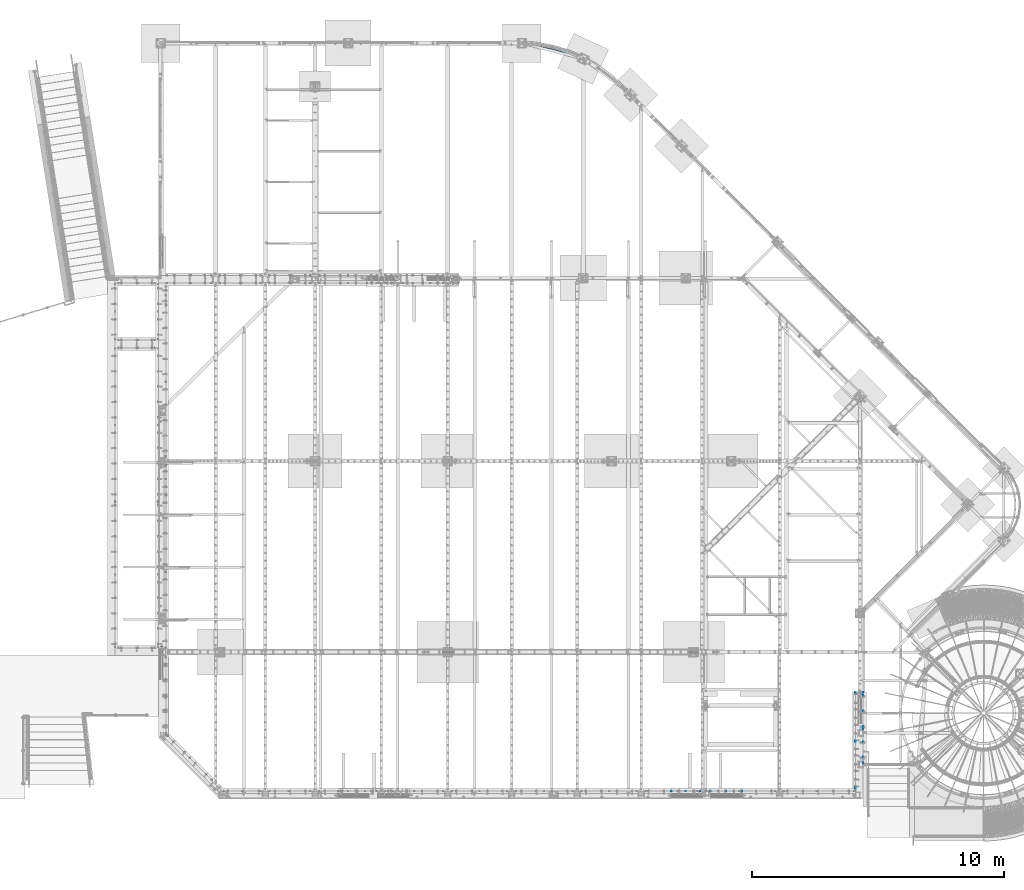
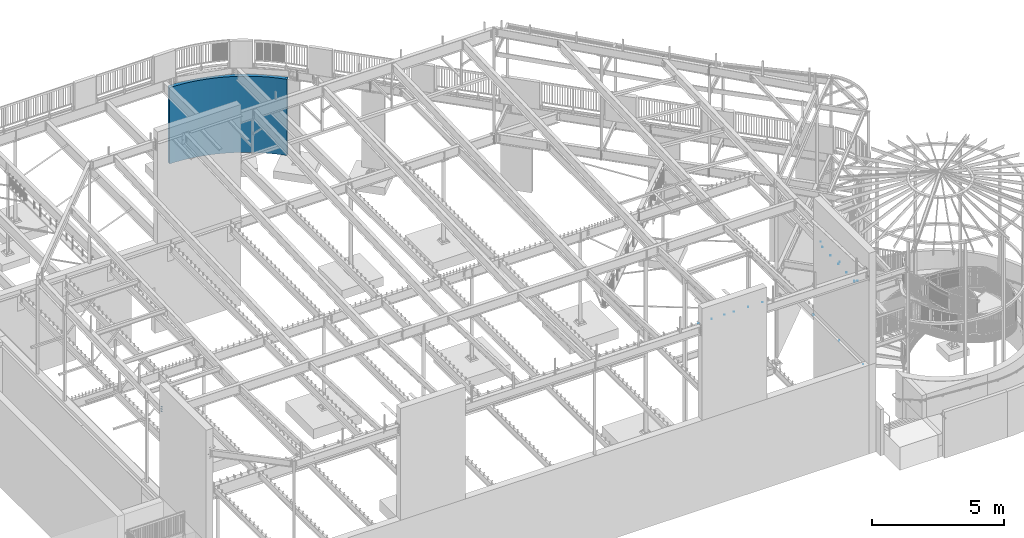
# One storey, part 942 of 975: 6 mechanical fasteners, 1 wall.
"""IFC2X3 building model written with IfcOpenShell, lengths in millimetres."""

from ifc_helpers import new_model, si_unit, frame, origin_with_axes, place, context, subcontext, project, spatial, faceted_brep, source, transform, mapped, material, type_object, element, save


model = new_model("IFC2X3")

# Units and contexts
model_context = context("Model", 3, precision=1e-05, world=origin_with_axes())
body_context = subcontext(model_context, "Body", "Model", "MODEL_VIEW")
ifc_project = project(units=[si_unit("LENGTHUNIT", "METRE", prefix="MILLI"), si_unit("AREAUNIT", "SQUARE_METRE"), si_unit("VOLUMEUNIT", "CUBIC_METRE"), si_unit("MASSUNIT", "GRAM", prefix="KILO"), si_unit("TIMEUNIT", "SECOND"), si_unit("PLANEANGLEUNIT", "RADIAN"), si_unit("SOLIDANGLEUNIT", "STERADIAN"), si_unit("THERMODYNAMICTEMPERATUREUNIT", "DEGREE_CELSIUS"), si_unit("LUMINOUSINTENSITYUNIT", "LUMEN")], contexts=[model_context])

# Site, building, storey
site_placement = place(None, origin_with_axes())
site = spatial("IfcSite", under=ifc_project, at=site_placement, CompositionType="ELEMENT")
building_placement = place(site_placement, origin_with_axes())
building = spatial("IfcBuilding", under=site, at=building_placement, Name="Undefined", CompositionType="ELEMENT")
storey_placement = place(building_placement, origin_with_axes())
storey = spatial("IfcBuildingStorey", under=building, at=storey_placement, Name="Undefined", CompositionType="ELEMENT", Elevation=0.0)

# Wall
ifc_material_1 = material(Name="CONCRETE/5000")
wall_type = type_object("IfcWallType", PredefinedType="NOTDEFINED")
wall_placement = place(storey_placement, frame((16265.9279473487, 29962.475, 1765.3), z_axis=(0.0, 0.0, 1.0), x_axis=(0.920632077807922, -0.390431270918542, 0.0)))
element("IfcWall", 1, at=wall_placement, inside=storey, type_object=wall_type, material=ifc_material_1, Name="STUD WALL", context=body_context, shape_type="Brep", body=[
    faceted_brep([(-29.014480485997, 70.4599171310983, -1765.3), (-29.014480485997, 70.4599171310983, 1765.3), (191.038909126074, 156.087803173992, 1765.3), (191.038909126074, 156.087803173992, -1765.3), (29.0144804859979, -70.4599171310911, 1765.3), (29.0144804859979, -70.4599171310911, -1765.3), (243.520305654064, 13.0092827090339, -1765.3), (243.520305654064, 13.0092827090339, 1765.3), (414.268430151377, 233.056693582781, 1765.3), (414.268430151377, 233.056693582781, -1765.3), (461.122191695533, 88.0377809226484, -1765.3), (461.122191695533, 88.0377809226484, 1765.3), (640.333502699951, 301.249157400722, 1765.3), (640.333502699951, 301.249157400722, -1765.3), (681.488144768097, 154.511106997277, -1765.3), (681.488144768097, 154.511106997277, 1765.3), (868.889220698546, 360.561153810486, 1765.3), (868.889220698546, 360.561153810486, -1765.3), (904.281953909582, 212.327842993349, -1765.3), (904.281953909582, 212.327842993349, 1765.3), (1099.58687811165, 410.902190868524, 1765.3), (1099.58687811165, 410.902190868524, -1765.3), (1129.16370399294, 261.39977827682, -1765.3), (1129.16370399294, 261.39977827682, 1765.3), (1332.07450096012, 452.19546356814, 1765.3), (1332.07450096012, 452.19546356814, -1765.3), (1355.79029433263, 301.652044101647, -1765.3), (1355.79029433263, 301.652044101647, 1765.3), (1565.99738432573, 484.377971020338, 1765.3), (1565.99738432573, 484.377971020338, -1765.3), (1583.8159621512, 333.023227836566, -1765.3), (1583.8159621512, 333.023227836566, 1765.3), (1800.99863352217, 507.400612573932, 1765.3), (1800.99863352217, 507.400612573932, -1765.3), (1812.8928101074, 355.465466661917, -1765.3), (1812.8928101074, 355.465466661917, 1765.3), (2036.71970860714, 521.228262728087, 1765.3), (2036.71970860714, 521.228262728087, -1765.3), (2042.67133708099, 368.944520593701, -1765.3), (2042.67133708099, 368.944520593701, 1765.3), (2272.80097140444, 525.839824723094, 1765.3), (2272.80097140444, 525.839824723094, -1765.3), (2272.80097140441, 373.439824723282, -1765.3), (2272.80097140441, 373.439824723282, 1765.3), (2508.88223420175, 521.22826272752, 1765.3), (2508.88223420175, 521.22826272752, -1765.3), (2502.93060572783, 368.944520593148, -1765.3), (2502.93060572783, 368.944520593148, 1765.3), (2744.60330928671, 507.40061257279, 1765.3), (2744.60330928671, 507.40061257279, -1765.3), (2732.70913270141, 355.465466660804, -1765.3), (2732.70913270141, 355.465466660804, 1765.3), (2979.60455848314, 484.377971018628, 1765.3), (2979.60455848314, 484.377971018628, -1765.3), (2961.78598065759, 333.023227834899, -1765.3), (2961.78598065759, 333.023227834899, 1765.3), (3213.52744184873, 452.195463565862, 1765.3), (3213.52744184873, 452.195463565862, -1765.3), (3189.81164847615, 301.652044099435, -1765.3), (3189.81164847615, 301.652044099435, 1765.3), (3446.01506469719, 410.902190865694, 1765.3), (3446.01506469719, 410.902190865694, -1765.3), (3416.43823881582, 261.399778274055, -1765.3), (3416.43823881582, 261.399778274055, 1765.3), (3676.71272211026, 360.561153807088, 1765.3), (3676.71272211026, 360.561153807088, -1765.3), (3641.31998889916, 212.327842990038, -1765.3), (3641.31998889916, 212.327842990038, 1765.3), (3905.26844010883, 301.249157396778, 1765.3), (3905.26844010883, 301.249157396778, -1765.3), (3864.11379804061, 154.511106993436, -1765.3), (3864.11379804061, 154.511106993436, 1765.3), (4131.33351265737, 233.056693578284, 1765.3), (4131.33351265737, 233.056693578284, -1765.3), (4084.47975111314, 88.037780918261, -1765.3), (4084.47975111314, 88.037780918261, 1765.3), (4354.56303368264, 156.087803168957, 1765.3), (4354.56303368264, 156.087803168957, -1765.3), (4302.08163715458, 13.0092827041299, -1765.3), (4302.08163715458, 13.0092827041299, 1765.3), (4574.61642329466, 70.4599171255322, 1765.3), (4574.61642329466, 70.4599171255322, -1765.3), (4516.5874623226, -70.4599171365116, 1765.3), (4516.5874623226, -70.4599171365116, -1765.3)], [[[0, 1, 2, 3]], [[4, 5, 6, 7]], [[5, 4, 1, 0]], [[3, 2, 8, 9]], [[7, 6, 10, 11]], [[9, 8, 12, 13]], [[11, 10, 14, 15]], [[13, 12, 16, 17]], [[15, 14, 18, 19]], [[17, 16, 20, 21]], [[19, 18, 22, 23]], [[21, 20, 24, 25]], [[23, 22, 26, 27]], [[25, 24, 28, 29]], [[27, 26, 30, 31]], [[29, 28, 32, 33]], [[31, 30, 34, 35]], [[33, 32, 36, 37]], [[35, 34, 38, 39]], [[37, 36, 40, 41]], [[39, 38, 42, 43]], [[41, 40, 44, 45]], [[43, 42, 46, 47]], [[45, 44, 48, 49]], [[47, 46, 50, 51]], [[49, 48, 52, 53]], [[51, 50, 54, 55]], [[53, 52, 56, 57]], [[55, 54, 58, 59]], [[57, 56, 60, 61]], [[59, 58, 62, 63]], [[61, 60, 64, 65]], [[63, 62, 66, 67]], [[65, 64, 68, 69]], [[67, 66, 70, 71]], [[69, 68, 72, 73]], [[71, 70, 74, 75]], [[73, 72, 76, 77]], [[75, 74, 78, 79]], [[77, 76, 80, 81]], [[76, 72, 68, 64, 60, 56, 52, 48, 44, 40, 36, 32, 28, 24, 20, 16, 12, 8, 2, 1, 4, 7, 11, 15, 19, 23, 27, 31, 35, 39, 43, 47, 51, 55, 59, 63, 67, 71, 75, 79, 82, 80]], [[79, 78, 83, 82]], [[78, 74, 70, 66, 62, 58, 54, 50, 46, 42, 38, 34, 30, 26, 22, 18, 14, 10, 6, 5, 0, 3, 9, 13, 17, 21, 25, 29, 33, 37, 41, 45, 49, 53, 57, 61, 65, 69, 73, 77, 81, 83]], [[82, 83, 81, 80]]]),
])

# Mechanical fasteners
ifc_material_2 = material(Name="Undefined")
mechanical_fastener_type = type_object("IfcMechanicalFastenerType", Name="Bolt assembly")
shared_shape_1 = source(origin_with_axes(), body_context, "Body", "Brep", [
    faceted_brep([(21.0805021442695, -33.3374996185303, 0.0), (10.5402510721348, -33.3374996185303, 18.2562503814697), (-10.5402510721347, -33.3374996185303, 18.2562503814697), (-21.0805021442695, -33.3374996185303, 2.58161694753986e-15), (-10.5402510721348, -33.3374996185303, -18.2562503814697), (10.5402510721347, -33.3374996185303, -18.2562503814697), (10.5402510721347, -19.84375, -18.2562503814697), (-10.5402510721348, -19.84375, -18.2562503814697), (-21.0805021442695, -19.84375, 2.58161694753986e-15), (-10.5402510721347, -19.84375, 18.2562503814697), (10.5402510721348, -19.84375, 18.2562503814697), (21.0805021442695, -19.84375, 0.0), (11.1125001907349, -19.84375, 0.0), (9.62370746473562, -19.84375, 5.55625009536776), (5.55625009536677, -19.84375, 9.62370746473619), (-1.1516283793199e-12, -19.84375, 11.1125001907349), (-5.55625009536876, -19.84375, 9.62370746473505), (-9.62370746473677, -19.84375, 5.55625009536577), (-11.1125001907349, -19.84375, -2.3032567586398e-12), (-9.62370746473447, -19.84375, -5.55625009536975), (-5.55625009536478, -19.84375, -9.62370746473734), (3.44254778438679e-12, -19.84375, -11.1125001907349), (5.55625009537075, -19.84375, -9.6237074647339), (9.62370746473792, -19.84375, -5.55625009536378), (9.62370746473792, 37.3062492458346, -5.55625009536378), (5.55625009537075, 37.3062492458346, -9.6237074647339), (3.44254778438679e-12, 37.3062492458346, -11.1125001907349), (-5.55625009536478, 37.3062492458346, -9.62370746473734), (-9.62370746473447, 37.3062492458346, -5.55625009536975), (-11.1125001907349, 37.3062492458346, -2.3032567586398e-12), (-9.62370746473677, 37.3062492458346, 5.55625009536577), (-5.55625009536876, 37.3062492458346, 9.62370746473505), (-1.1516283793199e-12, 37.3062492458346, 11.1125001907349), (5.55625009536677, 37.3062492458346, 9.62370746473619), (9.62370746473562, 37.3062492458346, 5.55625009536776), (11.1125001907349, 37.3062492458346, 0.0), (22.2250003814697, 3.96874999999636, 0.0), (19.2474149294712, 3.96874999999636, 11.1125001907355), (11.1125001907335, 3.96874999999636, 19.2474149294724), (-2.3032567586398e-12, 3.96874999999636, 22.2250003814697), (-11.1125001907375, 3.96874999999636, 19.2474149294701), (-19.2474149294735, 3.96874999999636, 11.1125001907315), (-22.2250003814697, 3.96874999999636, -4.60651351727959e-12), (-19.2474149294689, 3.96874999999636, -11.1125001907395), (-11.1125001907296, 3.96874999999636, -19.2474149294747), (6.88509556877358e-12, 3.96874999999636, -22.2250003814697), (11.1125001907415, 3.96874999999636, -19.2474149294678), (19.2474149294758, 3.96874999999636, -11.1125001907276), (19.2474149294758, 7.34218740462893, -11.1125001907276), (11.1125001907415, 7.34218740462893, -19.2474149294678), (6.88509556877358e-12, 7.34218740462893, -22.2250003814697), (-11.1125001907296, 7.34218740462893, -19.2474149294747), (-19.2474149294689, 7.34218740462893, -11.1125001907395), (-22.2250003814697, 7.34218740462893, -4.60651351727959e-12), (-19.2474149294735, 7.34218740462893, 11.1125001907315), (-11.1125001907375, 7.34218740462893, 19.2474149294701), (-2.3032567586398e-12, 7.34218740462893, 22.2250003814697), (11.1125001907335, 7.34218740462893, 19.2474149294724), (19.2474149294712, 7.34218740462893, 11.1125001907355), (22.2250003814697, 7.34218740462893, 0.0), (21.0805021442695, 7.34218740462893, 0.0), (10.5402510721348, 7.34218740462893, 18.2562503814697), (-10.5402510721347, 7.34218740462893, 18.2562503814697), (-21.0805021442695, 7.34218740462893, 2.58161694753986e-15), (-10.5402510721348, 7.34218740462893, -18.2562503814697), (10.5402510721347, 7.34218740462893, -18.2562503814697), (10.5402510721347, 29.5671877860987, -18.2562503814697), (-10.5402510721348, 29.5671877860987, -18.2562503814697), (-21.0805021442695, 29.5671877860987, 2.58161694753986e-15), (-10.5402510721347, 29.5671877860987, 18.2562503814697), (10.5402510721348, 29.5671877860987, 18.2562503814697), (21.0805021442695, 29.5671877860987, 0.0)], [[[0, 1, 2, 3, 4, 5]], [[6, 7, 8, 9, 10, 11]], [[0, 11, 10, 1]], [[1, 10, 9, 2]], [[2, 9, 8, 3]], [[3, 8, 7, 4]], [[4, 7, 6, 5]], [[5, 6, 11, 0]], [[12, 13, 14, 15, 16, 17, 18, 19, 20, 21, 22, 23]], [[24, 25, 26, 27, 28, 29, 30, 31, 32, 33, 34, 35]], [[12, 35, 34, 13]], [[13, 34, 33, 14]], [[14, 33, 32, 15]], [[15, 32, 31, 16]], [[16, 31, 30, 17]], [[17, 30, 29, 18]], [[18, 29, 28, 19]], [[19, 28, 27, 20]], [[20, 27, 26, 21]], [[21, 26, 25, 22]], [[22, 25, 24, 23]], [[23, 24, 35, 12]], [[36, 37, 38, 39, 40, 41, 42, 43, 44, 45, 46, 47]], [[48, 49, 50, 51, 52, 53, 54, 55, 56, 57, 58, 59]], [[36, 59, 58, 37]], [[37, 58, 57, 38]], [[38, 57, 56, 39]], [[39, 56, 55, 40]], [[40, 55, 54, 41]], [[41, 54, 53, 42]], [[42, 53, 52, 43]], [[43, 52, 51, 44]], [[44, 51, 50, 45]], [[45, 50, 49, 46]], [[46, 49, 48, 47]], [[47, 48, 59, 36]], [[60, 61, 62, 63, 64, 65]], [[66, 67, 68, 69, 70, 71]], [[60, 71, 70, 61]], [[61, 70, 69, 62]], [[62, 69, 68, 63]], [[63, 68, 67, 64]], [[64, 67, 66, 65]], [[65, 66, 71, 60]]]),
    faceted_brep([(11.90625, -4.0687499258398, 0.0), (10.3111149638083, -4.0687499258398, 5.95312500000036), (5.95312499999929, -4.0687499258398, 10.3111149638089), (-1.23388752809288e-12, -4.0687499258398, 11.90625), (-5.95312500000142, -4.0687499258398, 10.3111149638077), (-10.3111149638095, -4.0687499258398, 5.95312499999822), (-11.90625, -4.0687499258398, -2.46777505618577e-12), (-10.311114963807, -4.0687499258398, -5.95312500000249), (-5.95312499999716, -4.0687499258398, -10.3111149638101), (3.68844399139171e-12, -4.0687499258398, -11.90625), (5.95312500000355, -4.0687499258398, -10.3111149638064), (10.3111149638107, -4.0687499258398, -5.95312499999609), (10.3111149638107, 3.96874999999636, -5.95312499999609), (5.95312500000355, 3.96874999999636, -10.3111149638064), (3.68844399139171e-12, 3.96874999999636, -11.90625), (-5.95312499999716, 3.96874999999636, -10.3111149638101), (-10.311114963807, 3.96874999999636, -5.95312500000249), (-11.90625, 3.96874999999636, -2.46777505618577e-12), (-10.3111149638095, 3.96874999999636, 5.95312499999822), (-5.95312500000142, 3.96874999999636, 10.3111149638077), (-1.23388752809288e-12, 3.96874999999636, 11.90625), (5.95312499999929, 3.96874999999636, 10.3111149638089), (10.3111149638083, 3.96874999999636, 5.95312500000036), (11.90625, 3.96874999999636, 0.0), (11.90625, -19.74375, 0.0), (10.3111149638083, -19.74375, 5.95312500000036), (5.95312499999929, -19.74375, 10.3111149638089), (-1.23388752809288e-12, -19.74375, 11.90625), (-5.95312500000142, -19.74375, 10.3111149638077), (-10.3111149638095, -19.74375, 5.95312499999822), (-11.90625, -19.74375, -2.46777505618577e-12), (-10.311114963807, -19.74375, -5.95312500000249), (-5.95312499999716, -19.74375, -10.3111149638101), (3.68844399139171e-12, -19.74375, -11.90625), (5.95312500000355, -19.74375, -10.3111149638064), (10.3111149638107, -19.74375, -5.95312499999609), (10.3111149638107, -3.86874999991632, -5.95312499999609), (5.95312500000355, -3.86874999991632, -10.3111149638064), (3.68844399139171e-12, -3.86874999991632, -11.90625), (-5.95312499999716, -3.86874999991632, -10.3111149638101), (-10.311114963807, -3.86874999991632, -5.95312500000249), (-11.90625, -3.86874999991632, -2.46777505618577e-12), (-10.3111149638095, -3.86874999991632, 5.95312499999822), (-5.95312500000142, -3.86874999991632, 10.3111149638077), (-1.23388752809288e-12, -3.86874999991632, 11.90625), (5.95312499999929, -3.86874999991632, 10.3111149638089), (10.3111149638083, -3.86874999991632, 5.95312500000036), (11.90625, -3.86874999991632, 0.0)], [[[0, 1, 2, 3, 4, 5, 6, 7, 8, 9, 10, 11]], [[12, 13, 14, 15, 16, 17, 18, 19, 20, 21, 22, 23]], [[0, 23, 22, 1]], [[1, 22, 21, 2]], [[2, 21, 20, 3]], [[3, 20, 19, 4]], [[4, 19, 18, 5]], [[5, 18, 17, 6]], [[6, 17, 16, 7]], [[7, 16, 15, 8]], [[8, 15, 14, 9]], [[9, 14, 13, 10]], [[10, 13, 12, 11]], [[11, 12, 23, 0]], [[24, 25, 26, 27, 28, 29, 30, 31, 32, 33, 34, 35]], [[36, 37, 38, 39, 40, 41, 42, 43, 44, 45, 46, 47]], [[24, 47, 46, 25]], [[25, 46, 45, 26]], [[26, 45, 44, 27]], [[27, 44, 43, 28]], [[28, 43, 42, 29]], [[29, 42, 41, 30]], [[30, 41, 40, 31]], [[31, 40, 39, 32]], [[32, 39, 38, 33]], [[33, 38, 37, 34]], [[34, 37, 36, 35]], [[35, 36, 47, 24]]]),
])
mechanical_fastener_1_placement = place(storey_placement, frame((2143.12508094394, 6045.01552709396, 8162.30490112537), z_axis=(0.0, 0.999999863618581, 0.000522266999802014), x_axis=(0.0, 0.00052226699980215, -0.999999863618581)))
element("IfcMechanicalFastener", 2, at=mechanical_fastener_1_placement, inside=storey, type_object=mechanical_fastener_type, material=ifc_material_2, Name="Bolt assembly", NominalDiameter=22.2250003814697, NominalLength=57.1500015258789, context=body_context, shape_type="MappedRepresentation", body=[
    mapped(shared_shape_1, transform((0.0, 0.0, 0.0))),
    mapped(shared_shape_1, transform((76.1999969482422, 0.0, 0.0))),
    mapped(shared_shape_1, transform((152.399993896484, 0.0, 0.0))),
    mapped(shared_shape_1, transform((228.600006103516, 0.0, 0.0))),
])
shared_shape_2 = source(origin_with_axes(), body_context, "Body", "Brep", [
    faceted_brep([(3.17499995231628, -6.84956091845379e-10, 0.0), (2.74963061572023, -6.84956091845379e-10, 1.58749997615824), (1.58749997615795, -6.84956091845379e-10, 2.74963061572039), (-3.29036669216467e-13, -6.84956091845379e-10, 3.17499995231628), (-1.58749997615852, -6.84956091845379e-10, 2.74963061572006), (-2.74963061572056, -6.84956091845379e-10, 1.58749997615767), (-3.17499995231628, -6.84956091845379e-10, -6.58073338432935e-13), (-2.7496306157199, -6.84956091845379e-10, -1.58749997615881), (-1.58749997615738, -6.84956091845379e-10, -2.74963061572072), (9.83585049599157e-13, -6.84956091845379e-10, -3.17499995231628), (1.58749997615909, -6.84956091845379e-10, -2.74963061571974), (2.74963061572089, -6.84956091845379e-10, -1.5874999761571), (2.74963061572089, 8.03749999952222, -1.5874999761571), (1.58749997615909, 8.03749999952222, -2.74963061571974), (9.83585049599157e-13, 8.03749999952222, -3.17499995231628), (-1.58749997615738, 8.03749999952222, -2.74963061572072), (-2.7496306157199, 8.03749999952222, -1.58749997615881), (-3.17499995231628, 8.03749999952222, -6.58073338432935e-13), (-2.74963061572056, 8.03749999952222, 1.58749997615767), (-1.58749997615852, 8.03749999952222, 2.74963061572006), (-3.29036669216467e-13, 8.03749999952222, 3.17499995231628), (1.58749997615795, 8.03749999952222, 2.74963061572039), (2.74963061572023, 8.03749999952222, 1.58749997615824), (3.17499995231628, 8.03749999952222, 0.0)], [[[0, 1, 2, 3, 4, 5, 6, 7, 8, 9, 10, 11]], [[12, 13, 14, 15, 16, 17, 18, 19, 20, 21, 22, 23]], [[0, 23, 22, 1]], [[1, 22, 21, 2]], [[2, 21, 20, 3]], [[3, 20, 19, 4]], [[4, 19, 18, 5]], [[5, 18, 17, 6]], [[6, 17, 16, 7]], [[7, 16, 15, 8]], [[8, 15, 14, 9]], [[9, 14, 13, 10]], [[10, 13, 12, 11]], [[11, 12, 23, 0]]]),
])
mechanical_fastener_2_placement = place(storey_placement, frame((29967.2373507587, 1425.65191388594, 7046.27270074789), z_axis=(-7.0905516622588e-09, -0.0430877640020049, 0.999071291046494), x_axis=(-8.50000000943246e-08, 0.999071290960394, 0.0430877659982918)))
element("IfcMechanicalFastener", 3, at=mechanical_fastener_2_placement, inside=storey, type_object=mechanical_fastener_type, material=ifc_material_2, Name="Bolt assembly", NominalDiameter=6.34999990463257, NominalLength=7.9375, context=body_context, shape_type="MappedRepresentation", body=[
    mapped(shared_shape_2, transform((0.0, 0.0, 0.0))),
    mapped(shared_shape_2, transform((1346.19995117216, -1.77897163666785e-09, -1.36424205265939e-11))),
    mapped(shared_shape_2, transform((2794.00000000059, -3.69618646800518e-09, -2.81943357549608e-11))),
])
shared_shape_3 = source(origin_with_axes(), body_context, "Body", "Brep", [
    faceted_brep([(3.96875, -0.000311037082383336, 0.0), (3.43703832126942, -0.000311037082383336, 1.98437500000012), (1.98437499999976, -0.000311037082383336, 3.43703832126963), (-4.11295842697628e-13, -0.000311037082383336, 3.96875), (-1.98437500000047, -0.000311037082383336, 3.43703832126922), (-3.43703832126983, -0.000311037082383336, 1.98437499999941), (-3.96875, -0.000311037082383336, -8.22591685395256e-13), (-3.43703832126901, -0.000311037082383336, -1.98437500000083), (-1.98437499999905, -0.000311037082383336, -3.43703832127004), (1.2294813304639e-12, -0.000311037082383336, -3.96875), (1.98437500000118, -0.000311037082383336, -3.43703832126881), (3.43703832127024, -0.000311037082383336, -1.9843749999987), (3.43703832127024, 8.03718896291767, -1.9843749999987), (1.98437500000118, 8.03718896291767, -3.43703832126881), (1.2294813304639e-12, 8.03718896291767, -3.96875), (-1.98437499999905, 8.03718896291767, -3.43703832127004), (-3.43703832126901, 8.03718896291767, -1.98437500000083), (-3.96875, 8.03718896291767, -8.22591685395256e-13), (-3.43703832126983, 8.03718896291767, 1.98437499999941), (-1.98437500000047, 8.03718896291767, 3.43703832126922), (-4.11295842697628e-13, 8.03718896291767, 3.96875), (1.98437499999976, 8.03718896291767, 3.43703832126963), (3.43703832126942, 8.03718896291767, 1.98437500000012), (3.96875, 8.03718896291767, 0.0)], [[[0, 1, 2, 3, 4, 5, 6, 7, 8, 9, 10, 11]], [[12, 13, 14, 15, 16, 17, 18, 19, 20, 21, 22, 23]], [[0, 23, 22, 1]], [[1, 22, 21, 2]], [[2, 21, 20, 3]], [[3, 20, 19, 4]], [[4, 19, 18, 5]], [[5, 18, 17, 6]], [[6, 17, 16, 7]], [[7, 16, 15, 8]], [[8, 15, 14, 9]], [[9, 14, 13, 10]], [[10, 13, 12, 11]], [[11, 12, 23, 0]]]),
])
mechanical_fastener_3_placement = place(storey_placement, frame((24530.0499815415, 304.800313270969, 8420.1), z_axis=(-0.999999999999998, 6.90000001668524e-08, 0.0), x_axis=(0.0, 0.0, 1.0)))
element("IfcMechanicalFastener", 4, at=mechanical_fastener_3_placement, inside=storey, type_object=mechanical_fastener_type, material=ifc_material_2, Name="Bolt assembly", NominalDiameter=6.34999990463257, NominalLength=7.9375, context=body_context, shape_type="MappedRepresentation", body=[
    mapped(shared_shape_3, transform((0.0, 0.0, -625.474975585938))),
    mapped(shared_shape_3, transform((0.0, 0.0, 0.0))),
    mapped(shared_shape_3, transform((0.0, 0.0, 625.474975585938))),
])
shared_shape_4 = source(origin_with_axes(), body_context, "Body", "Brep", [
    faceted_brep([(3.96875, -0.000167202328036353, 0.0), (3.43703832126942, -0.000167202328036353, 1.98437500000012), (1.98437499999976, -0.000167202328036353, 3.43703832126963), (-4.11295842697628e-13, -0.000167202328036353, 3.96875), (-1.98437500000047, -0.000167202328036353, 3.43703832126922), (-3.43703832126983, -0.000167202328036353, 1.98437499999941), (-3.96875, -0.000167202328036353, -8.22591685395256e-13), (-3.43703832126901, -0.000167202328036353, -1.98437500000083), (-1.98437499999905, -0.000167202328036353, -3.43703832127004), (1.2294813304639e-12, -0.000167202328036353, -3.96875), (1.98437500000118, -0.000167202328036353, -3.43703832126881), (3.43703832127024, -0.000167202328036353, -1.9843749999987), (3.43703832127024, 8.03733279767203, -1.9843749999987), (1.98437500000118, 8.03733279767203, -3.43703832126881), (1.2294813304639e-12, 8.03733279767203, -3.96875), (-1.98437499999905, 8.03733279767203, -3.43703832127004), (-3.43703832126901, 8.03733279767203, -1.98437500000083), (-3.96875, 8.03733279767203, -8.22591685395256e-13), (-3.43703832126983, 8.03733279767203, 1.98437499999941), (-1.98437500000047, 8.03733279767203, 3.43703832126922), (-4.11295842697628e-13, 8.03733279767203, 3.96875), (1.98437499999976, 8.03733279767203, 3.43703832126963), (3.43703832126942, 8.03733279767203, 1.98437500000012), (3.96875, 8.03733279767203, 0.0)], [[[0, 1, 2, 3, 4, 5, 6, 7, 8, 9, 10, 11]], [[12, 13, 14, 15, 16, 17, 18, 19, 20, 21, 22, 23]], [[0, 23, 22, 1]], [[1, 22, 21, 2]], [[2, 21, 20, 3]], [[3, 20, 19, 4]], [[4, 19, 18, 5]], [[5, 18, 17, 6]], [[6, 17, 16, 7]], [[7, 16, 15, 8]], [[8, 15, 14, 9]], [[9, 14, 13, 10]], [[10, 13, 12, 11]], [[11, 12, 23, 0]]]),
])
mechanical_fastener_4_placement = place(storey_placement, frame((22929.8500432037, 304.800305271873, 8420.1), z_axis=(-0.999999999999998, 6.90000001668524e-08, 0.0), x_axis=(0.0, 0.0, 1.0)))
element("IfcMechanicalFastener", 5, at=mechanical_fastener_4_placement, inside=storey, type_object=mechanical_fastener_type, material=ifc_material_2, Name="Bolt assembly", NominalDiameter=6.34999990463257, NominalLength=7.9375, context=body_context, shape_type="MappedRepresentation", body=[
    mapped(shared_shape_4, transform((0.0, 0.0, -568.325012207031))),
    mapped(shared_shape_4, transform((0.0, 0.0, 0.0))),
    mapped(shared_shape_4, transform((0.0, 0.0, 568.325012207031))),
])
shared_shape_5 = source(origin_with_axes(), body_context, "Body", "Brep", [
    faceted_brep([(3.96875, -7.9374287518123, 0.0), (3.43703832126942, -7.9374287518123, 1.98437500000012), (1.98437499999976, -7.9374287518123, 3.43703832126963), (-4.11295842697628e-13, -7.9374287518123, 3.96875), (-1.98437500000047, -7.9374287518123, 3.43703832126922), (-3.43703832126983, -7.9374287518123, 1.98437499999941), (-3.96875, -7.9374287518123, -8.22591685395256e-13), (-3.43703832126901, -7.9374287518123, -1.98437500000083), (-1.98437499999905, -7.9374287518123, -3.43703832127004), (1.2294813304639e-12, -7.9374287518123, -3.96875), (1.98437500000118, -7.9374287518123, -3.43703832126881), (3.43703832127024, -7.9374287518123, -1.9843749999987), (3.43703832127024, 0.100071248187751, -1.9843749999987), (1.98437500000118, 0.100071248187751, -3.43703832126881), (1.2294813304639e-12, 0.100071248187751, -3.96875), (-1.98437499999905, 0.100071248187751, -3.43703832127004), (-3.43703832126901, 0.100071248187751, -1.98437500000083), (-3.96875, 0.100071248187751, -8.22591685395256e-13), (-3.43703832126983, 0.100071248187751, 1.98437499999941), (-1.98437500000047, 0.100071248187751, 3.43703832126922), (-4.11295842697628e-13, 0.100071248187751, 3.96875), (1.98437499999976, 0.100071248187751, 3.43703832126963), (3.43703832126942, 0.100071248187751, 1.98437500000012), (3.96875, 0.100071248187751, 0.0)], [[[0, 1, 2, 3, 4, 5, 6, 7, 8, 9, 10, 11]], [[12, 13, 14, 15, 16, 17, 18, 19, 20, 21, 22, 23]], [[0, 23, 22, 1]], [[1, 22, 21, 2]], [[2, 21, 20, 3]], [[3, 20, 19, 4]], [[4, 19, 18, 5]], [[5, 18, 17, 6]], [[6, 17, 16, 7]], [[7, 16, 15, 8]], [[8, 15, 14, 9]], [[9, 14, 13, 10]], [[10, 13, 12, 11]], [[11, 12, 23, 0]]]),
])
mechanical_fastener_5_placement = place(storey_placement, frame((29654.4998629002, 2324.09997666548, 3886.2), z_axis=(0.0, 1.0, 0.0), x_axis=(0.0, 0.0, 1.0)))
element("IfcMechanicalFastener", 6, at=mechanical_fastener_5_placement, inside=storey, type_object=mechanical_fastener_type, material=ifc_material_2, Name="Bolt assembly", NominalDiameter=6.34999990463257, NominalLength=7.9375, context=body_context, shape_type="MappedRepresentation", body=[
    mapped(shared_shape_5, transform((0.0, 0.0, -1879.59997558594))),
    mapped(shared_shape_5, transform((0.0, -4.36557456851006e-11, -50.8000000000575))),
    mapped(shared_shape_5, transform((0.0, 0.0, 1879.59997558594))),
])
shared_shape_6 = source(origin_with_axes(), body_context, "Body", "Brep", [
    faceted_brep([(10.3187503814697, -1.88977047343997e-07, 0.0), (8.93629996566297, -1.88977047343997e-07, 5.15937519073517), (5.15937519073425, -1.88977047343997e-07, 8.93629996566351), (-1.06936923054691e-12, -1.88977047343997e-07, 10.3187503814697), (-5.1593751907361, -1.88977047343997e-07, 8.93629996566244), (-8.93629996566404, -1.88977047343997e-07, 5.15937519073332), (-10.3187503814697, -1.88977047343997e-07, -2.13873846109383e-12), (-8.93629996566191, -1.88977047343997e-07, -5.15937519073702), (-5.1593751907324, -1.88977047343997e-07, -8.93629996566457), (3.19665157738187e-12, -1.88977047343997e-07, -10.3187503814697), (5.15937519073794, -1.88977047343997e-07, -8.93629996566137), (8.93629996566511, -1.88977047343997e-07, -5.15937519073147), (8.93629996566511, 6.44999998856618, -5.15937519073147), (5.15937519073794, 6.44999998856618, -8.93629996566137), (3.19665157738187e-12, 6.44999998856618, -10.3187503814697), (-5.1593751907324, 6.44999998856618, -8.93629996566457), (-8.93629996566191, 6.44999998856618, -5.15937519073702), (-10.3187503814697, 6.44999998856618, -2.13873846109383e-12), (-8.93629996566404, 6.44999998856618, 5.15937519073332), (-5.1593751907361, 6.44999998856618, 8.93629996566244), (-1.06936923054691e-12, 6.44999998856618, 10.3187503814697), (5.15937519073425, 6.44999998856618, 8.93629996566351), (8.93629996566297, 6.44999998856618, 5.15937519073517), (10.3187503814697, 6.44999998856618, 0.0)], [[[0, 1, 2, 3, 4, 5, 6, 7, 8, 9, 10, 11]], [[12, 13, 14, 15, 16, 17, 18, 19, 20, 21, 22, 23]], [[0, 23, 22, 1]], [[1, 22, 21, 2]], [[2, 21, 20, 3]], [[3, 20, 19, 4]], [[4, 19, 18, 5]], [[5, 18, 17, 6]], [[6, 17, 16, 7]], [[7, 16, 15, 8]], [[8, 15, 14, 9]], [[9, 14, 13, 10]], [[10, 13, 12, 11]], [[11, 12, 23, 0]]]),
])
mechanical_fastener_6_placement = place(storey_placement, frame((29965.6498508661, 1654.53463940612, 6890.89044573114), z_axis=(-7.0905516622588e-09, -0.0430877640020049, 0.999071291046494), x_axis=(-8.50000000943246e-08, 0.999071290960394, 0.0430877659982918)))
element("IfcMechanicalFastener", 7, at=mechanical_fastener_6_placement, inside=storey, type_object=mechanical_fastener_type, material=ifc_material_2, Name="Bolt assembly", NominalDiameter=15.875, NominalLength=6.34999990463257, context=body_context, shape_type="MappedRepresentation", body=[
    mapped(shared_shape_6, transform((0.0, 0.0, 0.0))),
    mapped(shared_shape_6, transform((609.599975585942, -8.29459168016911e-10, 0.0))),
    mapped(shared_shape_6, transform((1219.19995117188, -1.66255631484091e-09, 0.0))),
    mapped(shared_shape_6, transform((1828.80004882814, -2.49201548285782e-09, 0.0))),
    mapped(shared_shape_6, transform((2438.39990234377, -3.32511262968183e-09, 0.0))),
])

save(model, "model.ifc")
